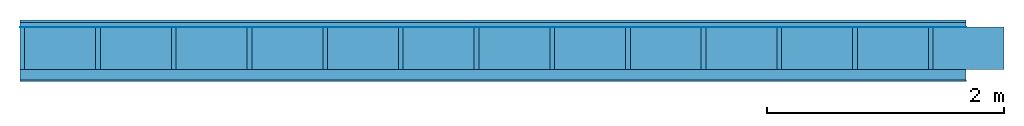
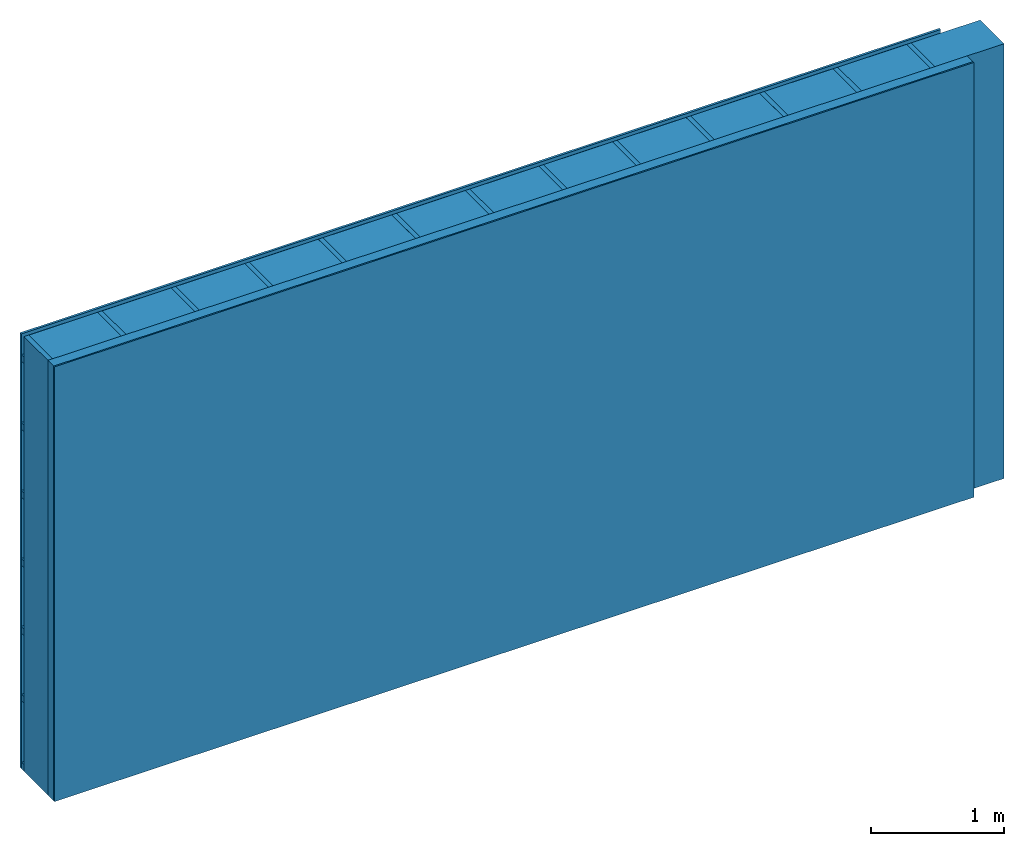
# One storey: 4 plates, 3 members, 1 element without a shape of its own.
"""IFC4 building model written with IfcOpenShell, lengths in metres."""

from ifc_helpers import new_model, si_unit, derived_unit, direction, frame, frame_2d, origin, origin_with_axes, place, context, project, spatial, rectangle, extrude, material, layer, layer_set, type_object, element, aggregate, save


model = new_model("IFC4")

# Units and contexts
plan_context = context("Plan", 3, precision=1e-05, world=origin(), true_north=direction((0.0, 1.0)))
model_context = context("Model", 3, precision=1e-05, world=origin(), true_north=direction((0.0, 1.0)))
ifc_project = project(units=[si_unit("LENGTHUNIT", "METRE"), derived_unit("SOUNDPRESSUREUNIT", [(si_unit("PRESSUREUNIT", "PASCAL", prefix="MICRO"), 0)]), si_unit("ENERGYUNIT", "JOULE", prefix="MEGA"), si_unit("MASSUNIT", "GRAM", prefix="KILO"), derived_unit("THERMALTRANSMITTANCEUNIT", [(si_unit("POWERUNIT", "WATT"), 1), (si_unit("AREAUNIT", "SQUARE_METRE"), -1), (si_unit("THERMODYNAMICTEMPERATUREUNIT", "KELVIN"), -1)]), derived_unit("AREADENSITYUNIT", [(si_unit("MASSUNIT", "GRAM", prefix="KILO"), 1), (si_unit("AREAUNIT", "SQUARE_METRE"), -1)]), derived_unit("USERDEFINED", [(si_unit("ENERGYUNIT", "JOULE", prefix="MEGA"), 1), (si_unit("AREAUNIT", "SQUARE_METRE"), -1)])], contexts=[plan_context, model_context])

# Site, building, storey
site = spatial("IfcSite", under=ifc_project)
building_placement = place(None, origin())
building = spatial("IfcBuilding", under=site, at=building_placement)
storey_placement = place(building_placement, origin())
storey = spatial("IfcBuildingStorey", under=building, at=storey_placement)

# Wall, members, plates
ifc_material_1 = material(Name="Wood cladding horizontal, closed")
ifc_layer_1 = layer(ifc_material_1, 0.02, Name="Cover 1st layer")
ifc_layer_2 = layer(None, 0.04, Name="Battens / profiles (ventilation)")
ifc_material_2 = material(Name="Vapor-permeable water barrier", Category="09.006")
ifc_layer_3 = layer(ifc_material_2, 0.0005, Name="outside 1st layer")
ifc_material_3 = material(Name="of the art")
ifc_layer_4 = layer(ifc_material_3, 0.0, Name="Bond")
ifc_layer_5 = layer(None, 0.36, Name="Support")
ifc_layer_6 = layer(ifc_material_3, 0.0, Name="Bond")
ifc_material_4 = material(Name="Solid timber panel")
ifc_layer_7 = layer(ifc_material_4, 0.087, Name="1st layer")
ifc_material_5 = material(Name="Plasterboard type A", Category="03.008")
ifc_layer_8 = layer(ifc_material_5, 0.0125, Name="Covering 1st layer")
ifc_material_6 = material(Name="joints", Category="04.017")
ifc_layer_9 = layer(ifc_material_6, 0.0, Name="Surface")
ifc_layer_set = layer_set([ifc_layer_1, ifc_layer_2, ifc_layer_3, ifc_layer_4, ifc_layer_5, ifc_layer_6, ifc_layer_7, ifc_layer_8, ifc_layer_9])
wall_type = type_object("IfcWallType", Name="D0988", PredefinedType="NOTDEFINED", material=ifc_layer_set)
wall_placement = place(None, frame((0.0, 0.0, 0.0), z_axis=(0.0, -1.0, 0.0), x_axis=(1.0, 0.0, 0.0)))
wall = element("IfcWall", 1, at=wall_placement, inside=storey, type_object=wall_type, material=ifc_layer_set, Name="Wall #1")
ifc_material_7 = material()
member_1_placement = place(wall_placement, origin())
member_1 = element("IfcMember", 2, at=member_1_placement, material=ifc_material_7, Name="Battens / profiles (ventilation)", context=plan_context, shape_type="SweptSolid", body=[
    extrude(rectangle(XDim=0.06, YDim=0.04, at=frame_2d((0.03, 0.02), x_axis=(1.0, 0.0))), frame((0.0, 0.0, 0.02), z_axis=(1.0, 0.0, 0.0), x_axis=(0.0, 1.0, 0.0)), (0.0, 0.0, 1.0), 8.0),
    extrude(rectangle(XDim=0.06, YDim=0.04, at=frame_2d((0.03, 0.02), x_axis=(1.0, 0.0))), frame((0.0, 0.625, 0.02), z_axis=(1.0, 0.0, 0.0), x_axis=(0.0, 1.0, 0.0)), (0.0, 0.0, 1.0), 8.0),
    extrude(rectangle(XDim=0.06, YDim=0.04, at=frame_2d((0.03, 0.02), x_axis=(1.0, 0.0))), frame((0.0, 1.25, 0.02), z_axis=(1.0, 0.0, 0.0), x_axis=(0.0, 1.0, 0.0)), (0.0, 0.0, 1.0), 8.0),
    extrude(rectangle(XDim=0.06, YDim=0.04, at=frame_2d((0.03, 0.02), x_axis=(1.0, 0.0))), frame((0.0, 1.875, 0.02), z_axis=(1.0, 0.0, 0.0), x_axis=(0.0, 1.0, 0.0)), (0.0, 0.0, 1.0), 8.0),
    extrude(rectangle(XDim=0.06, YDim=0.04, at=frame_2d((0.03, 0.02), x_axis=(1.0, 0.0))), frame((0.0, 2.5, 0.02), z_axis=(1.0, 0.0, 0.0), x_axis=(0.0, 1.0, 0.0)), (0.0, 0.0, 1.0), 8.0),
    extrude(rectangle(XDim=0.06, YDim=0.04, at=frame_2d((0.03, 0.02), x_axis=(1.0, 0.0))), frame((0.0, 3.125, 0.02), z_axis=(1.0, 0.0, 0.0), x_axis=(0.0, 1.0, 0.0)), (0.0, 0.0, 1.0), 8.0),
    extrude(rectangle(XDim=0.06, YDim=0.04, at=frame_2d((0.03, 0.02), x_axis=(1.0, 0.0))), frame((0.0, 3.75, 0.02), z_axis=(1.0, 0.0, 0.0), x_axis=(0.0, 1.0, 0.0)), (0.0, 0.0, 1.0), 8.0),
])
ifc_material_8 = material()
member_2_placement = place(wall_placement, origin())
member_2 = element("IfcMember", 3, at=member_2_placement, material=ifc_material_8, Name="Support", context=plan_context, shape_type="SweptSolid", body=[
    extrude(rectangle(XDim=0.04, YDim=0.36, at=frame_2d((0.02, 0.18), x_axis=(1.0, 0.0))), frame((0.0, 4.0, 0.0605), z_axis=(0.0, -1.0, 0.0), x_axis=(1.0, 0.0, 0.0)), (0.0, 0.0, 1.0), 4.0),
    extrude(rectangle(XDim=0.04, YDim=0.36, at=frame_2d((0.02, 0.18), x_axis=(1.0, 0.0))), frame((0.64, 4.0, 0.0605), z_axis=(0.0, -1.0, 0.0), x_axis=(1.0, 0.0, 0.0)), (0.0, 0.0, 1.0), 4.0),
    extrude(rectangle(XDim=0.04, YDim=0.36, at=frame_2d((0.02, 0.18), x_axis=(1.0, 0.0))), frame((1.28, 4.0, 0.0605), z_axis=(0.0, -1.0, 0.0), x_axis=(1.0, 0.0, 0.0)), (0.0, 0.0, 1.0), 4.0),
    extrude(rectangle(XDim=0.04, YDim=0.36, at=frame_2d((0.02, 0.18), x_axis=(1.0, 0.0))), frame((1.92, 4.0, 0.0605), z_axis=(0.0, -1.0, 0.0), x_axis=(1.0, 0.0, 0.0)), (0.0, 0.0, 1.0), 4.0),
    extrude(rectangle(XDim=0.04, YDim=0.36, at=frame_2d((0.02, 0.18), x_axis=(1.0, 0.0))), frame((2.56, 4.0, 0.0605), z_axis=(0.0, -1.0, 0.0), x_axis=(1.0, 0.0, 0.0)), (0.0, 0.0, 1.0), 4.0),
    extrude(rectangle(XDim=0.04, YDim=0.36, at=frame_2d((0.02, 0.18), x_axis=(1.0, 0.0))), frame((3.2, 4.0, 0.0605), z_axis=(0.0, -1.0, 0.0), x_axis=(1.0, 0.0, 0.0)), (0.0, 0.0, 1.0), 4.0),
    extrude(rectangle(XDim=0.04, YDim=0.36, at=frame_2d((0.02, 0.18), x_axis=(1.0, 0.0))), frame((3.84, 4.0, 0.0605), z_axis=(0.0, -1.0, 0.0), x_axis=(1.0, 0.0, 0.0)), (0.0, 0.0, 1.0), 4.0),
    extrude(rectangle(XDim=0.04, YDim=0.36, at=frame_2d((0.02, 0.18), x_axis=(1.0, 0.0))), frame((4.48, 4.0, 0.0605), z_axis=(0.0, -1.0, 0.0), x_axis=(1.0, 0.0, 0.0)), (0.0, 0.0, 1.0), 4.0),
    extrude(rectangle(XDim=0.04, YDim=0.36, at=frame_2d((0.02, 0.18), x_axis=(1.0, 0.0))), frame((5.12, 4.0, 0.0605), z_axis=(0.0, -1.0, 0.0), x_axis=(1.0, 0.0, 0.0)), (0.0, 0.0, 1.0), 4.0),
    extrude(rectangle(XDim=0.04, YDim=0.36, at=frame_2d((0.02, 0.18), x_axis=(1.0, 0.0))), frame((5.76, 4.0, 0.0605), z_axis=(0.0, -1.0, 0.0), x_axis=(1.0, 0.0, 0.0)), (0.0, 0.0, 1.0), 4.0),
    extrude(rectangle(XDim=0.04, YDim=0.36, at=frame_2d((0.02, 0.18), x_axis=(1.0, 0.0))), frame((6.4, 4.0, 0.0605), z_axis=(0.0, -1.0, 0.0), x_axis=(1.0, 0.0, 0.0)), (0.0, 0.0, 1.0), 4.0),
    extrude(rectangle(XDim=0.04, YDim=0.36, at=frame_2d((0.02, 0.18), x_axis=(1.0, 0.0))), frame((7.04, 4.0, 0.0605), z_axis=(0.0, -1.0, 0.0), x_axis=(1.0, 0.0, 0.0)), (0.0, 0.0, 1.0), 4.0),
    extrude(rectangle(XDim=0.04, YDim=0.36, at=frame_2d((0.02, 0.18), x_axis=(1.0, 0.0))), frame((7.68, 4.0, 0.0605), z_axis=(0.0, -1.0, 0.0), x_axis=(1.0, 0.0, 0.0)), (0.0, 0.0, 1.0), 4.0),
])
ifc_material_9 = material(Name="Mineral wool")
member_3_placement = place(wall_placement, origin())
member_3 = element("IfcMember", 4, at=member_3_placement, material=ifc_material_9, Name="Cavity", context=plan_context, shape_type="SweptSolid", body=[
    extrude(rectangle(XDim=0.6, YDim=0.36, at=frame_2d((0.3, 0.18), x_axis=(1.0, 0.0))), frame((0.04, 4.0, 0.0605), z_axis=(0.0, -1.0, 0.0), x_axis=(1.0, 0.0, 0.0)), (0.0, 0.0, 1.0), 4.0),
    extrude(rectangle(XDim=0.6, YDim=0.36, at=frame_2d((0.3, 0.18), x_axis=(1.0, 0.0))), frame((0.68, 4.0, 0.0605), z_axis=(0.0, -1.0, 0.0), x_axis=(1.0, 0.0, 0.0)), (0.0, 0.0, 1.0), 4.0),
    extrude(rectangle(XDim=0.6, YDim=0.36, at=frame_2d((0.3, 0.18), x_axis=(1.0, 0.0))), frame((1.32, 4.0, 0.0605), z_axis=(0.0, -1.0, 0.0), x_axis=(1.0, 0.0, 0.0)), (0.0, 0.0, 1.0), 4.0),
    extrude(rectangle(XDim=0.6, YDim=0.36, at=frame_2d((0.3, 0.18), x_axis=(1.0, 0.0))), frame((1.96, 4.0, 0.0605), z_axis=(0.0, -1.0, 0.0), x_axis=(1.0, 0.0, 0.0)), (0.0, 0.0, 1.0), 4.0),
    extrude(rectangle(XDim=0.6, YDim=0.36, at=frame_2d((0.3, 0.18), x_axis=(1.0, 0.0))), frame((2.6, 4.0, 0.0605), z_axis=(0.0, -1.0, 0.0), x_axis=(1.0, 0.0, 0.0)), (0.0, 0.0, 1.0), 4.0),
    extrude(rectangle(XDim=0.6, YDim=0.36, at=frame_2d((0.3, 0.18), x_axis=(1.0, 0.0))), frame((3.24, 4.0, 0.0605), z_axis=(0.0, -1.0, 0.0), x_axis=(1.0, 0.0, 0.0)), (0.0, 0.0, 1.0), 4.0),
    extrude(rectangle(XDim=0.6, YDim=0.36, at=frame_2d((0.3, 0.18), x_axis=(1.0, 0.0))), frame((3.88, 4.0, 0.0605), z_axis=(0.0, -1.0, 0.0), x_axis=(1.0, 0.0, 0.0)), (0.0, 0.0, 1.0), 4.0),
    extrude(rectangle(XDim=0.6, YDim=0.36, at=frame_2d((0.3, 0.18), x_axis=(1.0, 0.0))), frame((4.52, 4.0, 0.0605), z_axis=(0.0, -1.0, 0.0), x_axis=(1.0, 0.0, 0.0)), (0.0, 0.0, 1.0), 4.0),
    extrude(rectangle(XDim=0.6, YDim=0.36, at=frame_2d((0.3, 0.18), x_axis=(1.0, 0.0))), frame((5.16, 4.0, 0.0605), z_axis=(0.0, -1.0, 0.0), x_axis=(1.0, 0.0, 0.0)), (0.0, 0.0, 1.0), 4.0),
    extrude(rectangle(XDim=0.6, YDim=0.36, at=frame_2d((0.3, 0.18), x_axis=(1.0, 0.0))), frame((5.8, 4.0, 0.0605), z_axis=(0.0, -1.0, 0.0), x_axis=(1.0, 0.0, 0.0)), (0.0, 0.0, 1.0), 4.0),
    extrude(rectangle(XDim=0.6, YDim=0.36, at=frame_2d((0.3, 0.18), x_axis=(1.0, 0.0))), frame((6.44, 4.0, 0.0605), z_axis=(0.0, -1.0, 0.0), x_axis=(1.0, 0.0, 0.0)), (0.0, 0.0, 1.0), 4.0),
    extrude(rectangle(XDim=0.6, YDim=0.36, at=frame_2d((0.3, 0.18), x_axis=(1.0, 0.0))), frame((7.08, 4.0, 0.0605), z_axis=(0.0, -1.0, 0.0), x_axis=(1.0, 0.0, 0.0)), (0.0, 0.0, 1.0), 4.0),
    extrude(rectangle(XDim=0.6, YDim=0.36, at=frame_2d((0.3, 0.18), x_axis=(1.0, 0.0))), frame((7.72, 4.0, 0.0605), z_axis=(0.0, -1.0, 0.0), x_axis=(1.0, 0.0, 0.0)), (0.0, 0.0, 1.0), 4.0),
])
plate_1_placement = place(wall_placement, origin())
plate_1 = element("IfcPlate", 5, at=plate_1_placement, material=ifc_material_1, Name="Cover 1st layer", context=plan_context, shape_type="SweptSolid", body=[
    extrude(rectangle(XDim=8.0, YDim=4.0, at=frame_2d((4.0, 2.0), x_axis=(1.0, 0.0))), origin_with_axes(), (0.0, 0.0, 1.0), 0.02),
])
plate_2_placement = place(wall_placement, origin())
plate_2 = element("IfcPlate", 6, at=plate_2_placement, material=ifc_material_2, Name="outside 1st layer", context=plan_context, shape_type="SweptSolid", body=[
    extrude(rectangle(XDim=8.0, YDim=4.0, at=frame_2d((4.0, 2.0), x_axis=(1.0, 0.0))), frame((0.0, 0.0, 0.06), z_axis=(0.0, 0.0, 1.0), x_axis=(1.0, 0.0, 0.0)), (0.0, 0.0, 1.0), 0.0005),
])
plate_3_placement = place(wall_placement, origin())
plate_3 = element("IfcPlate", 7, at=plate_3_placement, material=ifc_material_4, Name="1st layer", context=plan_context, shape_type="SweptSolid", body=[
    extrude(rectangle(XDim=8.0, YDim=4.0, at=frame_2d((4.0, 2.0), x_axis=(1.0, 0.0))), frame((0.0, 0.0, 0.4205), z_axis=(0.0, 0.0, 1.0), x_axis=(1.0, 0.0, 0.0)), (0.0, 0.0, 1.0), 0.087),
])
plate_4_placement = place(wall_placement, origin())
plate_4 = element("IfcPlate", 8, at=plate_4_placement, material=ifc_material_5, Name="Covering 1st layer", context=plan_context, shape_type="SweptSolid", body=[
    extrude(rectangle(XDim=8.0, YDim=4.0, at=frame_2d((4.0, 2.0), x_axis=(1.0, 0.0))), frame((0.0, 0.0, 0.5075), z_axis=(0.0, 0.0, 1.0), x_axis=(1.0, 0.0, 0.0)), (0.0, 0.0, 1.0), 0.0125),
])
aggregate(wall, [plate_1, member_1, plate_2, member_2, member_3, plate_3, plate_4])

save(model, "model.ifc")
